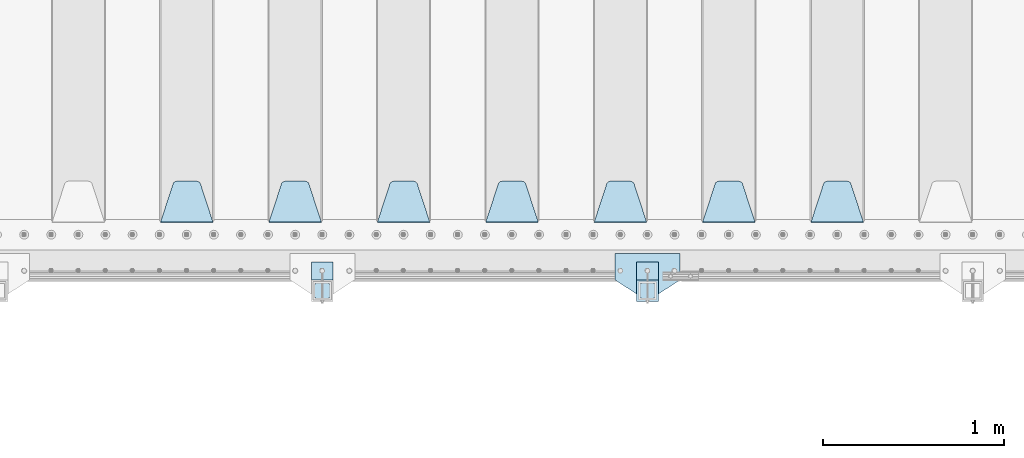
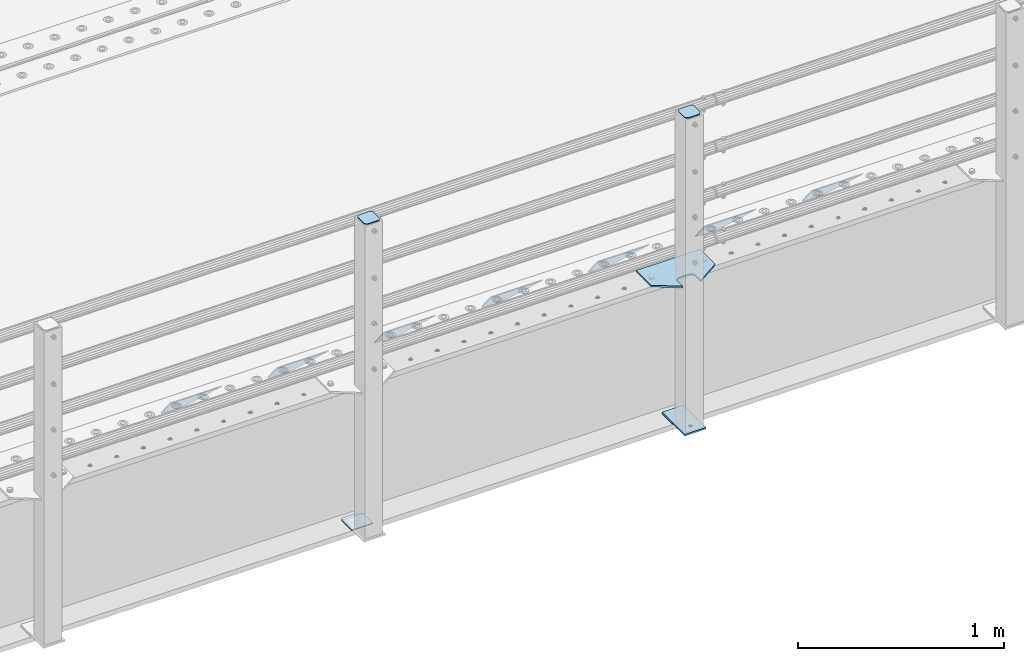
# One storey, part 203 of 247: 13 plates.
"""IFC2X3 building model written with IfcOpenShell, lengths in millimetres."""

import ifcopenshell
import ifcopenshell.guid

model = None  # the IFC model being written
_history = None  # IfcOwnerHistory: only IFC2X3 demands one
_inside = {}  # id of a spatial element -> (the spatial element, [elements in it])
_under = {}  # id of a project, library or spatial element -> (it, [spatial elements below it])
_declared = {}  # id of a project -> (the project, [libraries it declares])
_typed = {}  # id of a type object -> (the type object, [elements of that type])
_made_of = {}  # id of a material, layer set ... -> (it, [elements and type objects made of it])


def new_model(schema):
    """Start an empty IFC model of exactly this schema.

    Asked for "IFC4X3", IfcOpenShell would pick the latest addendum, in which some entities
    have other attributes; the version numbers below select the first issue.
    IFC2X3 requires an IfcOwnerHistory on every rooted entity: one is made here for all.
    """
    global model, _history
    if schema == "IFC4X3":
        model = ifcopenshell.file(schema_version=(4, 3, 0, 0))
    else:
        model = ifcopenshell.file(schema=schema)
    _inside.clear()
    _under.clear()
    _declared.clear()
    _typed.clear()
    _made_of.clear()
    _history = None
    if model.schema == "IFC2X3":
        org = make("IfcOrganization", Name="unknown")
        user = make(
            "IfcPersonAndOrganization",
            ThePerson=make("IfcPerson", FamilyName="unknown"),
            TheOrganization=org,
        )
        app = make(
            "IfcApplication",
            ApplicationDeveloper=org,
            Version="unknown",
            ApplicationFullName="unknown",
            ApplicationIdentifier="unknown",
        )
        _history = make(
            "IfcOwnerHistory",
            OwningUser=user,
            OwningApplication=app,
            ChangeAction="ADDED",
            CreationDate=0,
        )
    return model


def make(cls, **values):
    """One entity of the class cls with the attributes given. An attribute that is None is left unset."""
    return model.create_entity(
        cls, **{name: value for name, value in values.items() if value is not None}
    )


def rooted(cls, **values):
    """An entity with a GlobalId (a new one), such as an element, a storey or a relation."""
    return make(cls, GlobalId=ifcopenshell.guid.new(), OwnerHistory=_history, **values)


def si_unit(unit_type, name, prefix=None):
    """IfcSIUnit, for example si_unit("LENGTHUNIT", "METRE", prefix="MILLI")."""
    return make("IfcSIUnit", UnitType=unit_type, Prefix=prefix, Name=name)


def assignment(units):
    """IfcUnitAssignment: the units of a project."""
    return None if units is None else make("IfcUnitAssignment", Units=units)


def point(xyz):
    """IfcCartesianPoint."""
    return None if xyz is None else make("IfcCartesianPoint", Coordinates=xyz)


def direction(xyz):
    """IfcDirection."""
    return None if xyz is None else make("IfcDirection", DirectionRatios=xyz)


def frame(location, z_axis=None, x_axis=None):
    """IfcAxis2Placement3D, a coordinate frame: its origin and axes. An axis left out is left unset."""
    return make(
        "IfcAxis2Placement3D",
        Location=point(location),
        Axis=direction(z_axis),
        RefDirection=direction(x_axis),
    )


def origin_with_axes():
    """The frame at (0, 0, 0) with the z axis (0, 0, 1) and the x axis (1, 0, 0) written out."""
    return frame((0.0, 0.0, 0.0), z_axis=(0.0, 0.0, 1.0), x_axis=(1.0, 0.0, 0.0))


def place(relative_to, where):
    """IfcLocalPlacement: puts the frame where relative to a parent placement (None: the world)."""
    return make(
        "IfcLocalPlacement", PlacementRelTo=relative_to, RelativePlacement=where
    )


def context(
    kind, dimensions, precision=None, world=None, true_north=None, identifier=None
):
    """IfcGeometricRepresentationContext, for example the 3D "Model" context."""
    return make(
        "IfcGeometricRepresentationContext",
        ContextIdentifier=identifier,
        ContextType=kind,
        CoordinateSpaceDimension=dimensions,
        Precision=precision,
        WorldCoordinateSystem=world,
        TrueNorth=true_north,
    )


def subcontext(parent, identifier, kind, view, scale=None):
    """IfcGeometricRepresentationSubContext, for example "Body" below "Model"."""
    return make(
        "IfcGeometricRepresentationSubContext",
        ContextIdentifier=identifier,
        ContextType=kind,
        ParentContext=parent,
        TargetScale=scale,
        TargetView=view,
    )


def project(units=None, contexts=None):
    """IfcProject with its units and contexts."""
    return rooted(
        "IfcProject",
        Name="project",
        RepresentationContexts=contexts,
        UnitsInContext=assignment(units),
    )


def spatial(cls, under=None, at=None, **own):
    """A site, building, storey or space (cls), placed at a placement, below another one or the project."""
    s = rooted(cls, ObjectPlacement=at, **own)
    if under is not None:
        _under.setdefault(under.id(), (under, []))[1].append(s)
    return s


def faces_of(points, faces, orient=None, outer=None):
    """IfcFace entities. A face is a list of loops; a loop is a list of indices into points, from 0.

    orient and outer hold one flag for each loop. By default every Orientation is true, the
    first loop of a face is its IfcFaceOuterBound and the others are IfcFaceBound.
    """
    made = []
    for i, loops in enumerate(faces):
        bounds = []
        for j, loop in enumerate(loops):
            is_outer = j == 0 if outer is None else outer[i][j]
            bounds.append(
                make(
                    "IfcFaceOuterBound" if is_outer else "IfcFaceBound",
                    Bound=make("IfcPolyLoop", Polygon=[points[k] for k in loop]),
                    Orientation=True if orient is None else orient[i][j],
                )
            )
        made.append(make("IfcFace", Bounds=bounds))
    return made


def faceted_brep(points, faces, orient=None, outer=None, voids=None):
    """IfcFacetedBrep: a solid bounded by flat faces; with voids (closed shells), ...WithVoids."""
    shared = [point(p) for p in points]
    hull = make("IfcClosedShell", CfsFaces=faces_of(shared, faces, orient, outer))
    if voids is None:
        return make("IfcFacetedBrep", Outer=hull)
    return make(
        "IfcFacetedBrepWithVoids",
        Outer=hull,
        Voids=[
            make(cls, CfsFaces=faces_of(shared, fs, o, b)) for cls, fs, o, b in voids
        ],
    )


def shape(context_of_items, identifier, shape_type, items):
    """IfcShapeRepresentation: the items that make up one representation, for example the "Body"."""
    return make(
        "IfcShapeRepresentation",
        ContextOfItems=context_of_items,
        RepresentationIdentifier=identifier,
        RepresentationType=shape_type,
        Items=items,
    )


def material(Name=None, Category=None):
    """IfcMaterial."""
    return make("IfcMaterial", Name=Name, Category=Category)


def made_of(thing, what):
    """Note that an element or type object is made of a material, layer set ...; save() writes the relation."""
    if what is not None:
        _made_of.setdefault(what.id(), (what, []))[1].append(thing)
    return thing


def type_object(cls, material=None, **own):
    """A type object (cls), such as IfcWallType, which elements share."""
    return made_of(rooted(cls, **own), material)


def element(
    cls,
    number,
    at=None,
    inside=None,
    cuts=None,
    type_object=None,
    material=None,
    context=None,
    identifier="Body",
    shape_type=None,
    held_by="IfcProductDefinitionShape",
    body=None,
    shapes=None,
    **own,
):
    """One element of the class cls, such as IfcWall. Its Tag is "e" and its number.

    at: its placement. inside: the storey or other place that contains it. cuts: it is an
    opening in that element (IfcRelVoidsElement). A single representation is given by context,
    identifier, shape_type and body (its items); several are given by shapes. held_by: the class
    of the entity that holds the representations. save() writes the other relations.
    """
    e = rooted(cls, Tag="e%d" % number, ObjectPlacement=at, **own)
    if body is not None:
        shapes = [shape(context, identifier, shape_type, body)]
    if shapes is not None:
        e.Representation = make(held_by, Representations=shapes)
    if inside is not None:
        _inside.setdefault(inside.id(), (inside, []))[1].append(e)
    if cuts is not None:
        rooted(
            "IfcRelVoidsElement", RelatingBuildingElement=cuts, RelatedOpeningElement=e
        )
    if type_object is not None:
        _typed.setdefault(type_object.id(), (type_object, []))[1].append(e)
    return made_of(e, material)


def aggregate(whole, parts):
    """IfcRelAggregates: a whole, such as a stair, and the parts it consists of."""
    return rooted("IfcRelAggregates", RelatingObject=whole, RelatedObjects=parts)


def save(model, path):
    """Write the relations noted so far, then the file.

    IfcRelAggregates (storeys below a building ...), IfcRelContainedInSpatialStructure (elements
    in a storey), IfcRelDefinesByType, IfcRelAssociatesMaterial and IfcRelDeclares: one each for
    every whole, place, type object, material and project.
    """
    for whole, parts in _under.values():
        aggregate(whole, parts)
    for where, things in _inside.values():
        rooted(
            "IfcRelContainedInSpatialStructure",
            RelatedElements=things,
            RelatingStructure=where,
        )
    for kind, things in _typed.values():
        rooted("IfcRelDefinesByType", RelatedObjects=things, RelatingType=kind)
    for what, things in _made_of.values():
        rooted("IfcRelAssociatesMaterial", RelatedObjects=things, RelatingMaterial=what)
    for by, libraries in _declared.values():
        rooted("IfcRelDeclares", RelatingContext=by, RelatedDefinitions=libraries)
    model.write(path)


model = new_model("IFC2X3")

# Units and contexts
model_context = context("Model", 3, precision=1e-05, world=origin_with_axes())
body_context = subcontext(model_context, "Body", "Model", "MODEL_VIEW")
ifc_project = project(units=[si_unit("LENGTHUNIT", "METRE", prefix="MILLI"), si_unit("AREAUNIT", "SQUARE_METRE"), si_unit("VOLUMEUNIT", "CUBIC_METRE"), si_unit("MASSUNIT", "GRAM", prefix="KILO"), si_unit("TIMEUNIT", "SECOND"), si_unit("PLANEANGLEUNIT", "RADIAN"), si_unit("SOLIDANGLEUNIT", "STERADIAN"), si_unit("THERMODYNAMICTEMPERATUREUNIT", "DEGREE_CELSIUS"), si_unit("LUMINOUSINTENSITYUNIT", "LUMEN")], contexts=[model_context])

# Site, building, storey
site_placement = place(None, origin_with_axes())
site = spatial("IfcSite", under=ifc_project, at=site_placement, CompositionType="ELEMENT")
building_placement = place(site_placement, origin_with_axes())
building = spatial("IfcBuilding", under=site, at=building_placement, Name="Standard", CompositionType="ELEMENT")
storey_placement = place(building_placement, origin_with_axes())
storey = spatial("IfcBuildingStorey", under=building, at=storey_placement, Name="Undefined", CompositionType="ELEMENT", Elevation=0.0)

# Plates
ifc_material_1 = material(Name="STEEL/S355N")
plate_type_1 = type_object("IfcPlateType", PredefinedType="NOTDEFINED")
plate_1_placement = place(storey_placement, frame((10745.0, 168.232233047034, -1.76776695296758), z_axis=(0.0, 0.707106781186548, -0.707106781186547), x_axis=(-1.0, 0.0, 0.0)))
element("IfcPlate", 1, at=plate_1_placement, inside=storey, type_object=plate_type_1, material=ifc_material_1, context=body_context, shape_type="Brep", body=[
    faceted_brep([(0.0, -2.49999999999909, 0.0), (69.345504679477, -2.5, 300.17173142483), (69.345504679477, 2.50000000000091, 300.171731424831), (0.0, 2.5, -9.09494701772928e-13), (70.9274061199576, -2.5, 304.897442415399), (70.9274061199576, 2.50000000000091, 304.8974424154), (73.3818627772307, -2.49999999999909, 309.234538108527), (73.3818627772307, 2.5, 309.234538108526), (76.6187032999551, -2.5, 313.023683126102), (76.6187032999551, 2.50000000000091, 313.023683126102), (80.5190132704993, -2.49999999999909, 316.125672595371), (80.5190132704993, 2.50000000000091, 316.125672595372), (84.9395038596849, -2.49999999999909, 318.426546230476), (84.9395038596849, 2.5, 318.426546230475), (89.7177759439219, -2.5, 319.841774983274), (89.7177759439219, 2.50000000000091, 319.841774983275), (94.678286292652, -2.5, 320.319366455077), (94.678286292652, 2.50000000000091, 320.319366455077), (195.321713707348, -2.5, 320.319366455077), (195.321713707348, 2.50000000000091, 320.319366455077), (200.282224056078, -2.5, 319.841774983274), (200.282224056078, 2.50000000000091, 319.841774983275), (205.060496140315, -2.5, 318.426546230475), (205.060496140315, 2.5, 318.426546230474), (209.480986729501, -2.49999999999818, 316.12567259537), (209.480986729501, 2.50000000000091, 316.12567259537), (213.381296700045, -2.5, 313.023683126101), (213.381296700045, 2.50000000000091, 313.023683126101), (216.618137222769, -2.5, 309.234538108525), (216.618137222769, 2.5, 309.234538108525), (219.072593880042, -2.49999999999909, 304.897442415398), (219.072593880042, 2.5, 304.897442415398), (220.654495320523, -2.5, 300.17173142483), (220.654495320523, 2.50000000000091, 300.171731424831), (290.0, -2.49999999999909, 0.0), (290.0, 2.5, -9.09494701772928e-13)], [[[0, 1, 2, 3]], [[1, 4, 5, 2]], [[4, 6, 7, 5]], [[6, 8, 9, 7]], [[8, 10, 11, 9]], [[10, 12, 13, 11]], [[12, 14, 15, 13]], [[14, 16, 17, 15]], [[16, 18, 19, 17]], [[18, 20, 21, 19]], [[20, 22, 23, 21]], [[22, 24, 25, 23]], [[24, 26, 27, 25]], [[26, 28, 29, 27]], [[28, 30, 31, 29]], [[30, 32, 33, 31]], [[32, 34, 35, 33]], [[34, 0, 3, 35]], [[5, 7, 9, 11, 13, 15, 17, 19, 21, 23, 25, 27, 29, 31, 33, 35, 3, 2]], [[34, 32, 30, 28, 26, 24, 22, 20, 18, 16, 14, 12, 10, 8, 6, 4, 1, 0]]]),
])
plate_2_placement = place(storey_placement, frame((10145.0, 168.232233047034, -1.76776695296758), z_axis=(0.0, 0.707106781186548, -0.707106781186547), x_axis=(-1.0, 0.0, 0.0)))
element("IfcPlate", 2, at=plate_2_placement, inside=storey, type_object=plate_type_1, material=ifc_material_1, context=body_context, shape_type="Brep", body=[
    faceted_brep([(0.0, -2.49999999999909, 0.0), (69.345504679477, -2.5, 300.17173142483), (69.345504679477, 2.50000000000091, 300.171731424831), (0.0, 2.5, -9.09494701772928e-13), (70.9274061199576, -2.5, 304.897442415399), (70.9274061199576, 2.50000000000091, 304.8974424154), (73.3818627772307, -2.49999999999909, 309.234538108527), (73.3818627772307, 2.5, 309.234538108526), (76.6187032999551, -2.5, 313.023683126102), (76.6187032999551, 2.50000000000091, 313.023683126102), (80.5190132704993, -2.49999999999909, 316.125672595371), (80.5190132704993, 2.50000000000091, 316.125672595372), (84.9395038596849, -2.49999999999909, 318.426546230476), (84.9395038596849, 2.5, 318.426546230475), (89.7177759439219, -2.5, 319.841774983274), (89.7177759439219, 2.50000000000091, 319.841774983275), (94.678286292652, -2.5, 320.319366455077), (94.678286292652, 2.50000000000091, 320.319366455077), (195.321713707348, -2.5, 320.319366455077), (195.321713707348, 2.50000000000091, 320.319366455077), (200.282224056078, -2.5, 319.841774983274), (200.282224056078, 2.50000000000091, 319.841774983275), (205.060496140315, -2.5, 318.426546230475), (205.060496140315, 2.5, 318.426546230474), (209.480986729501, -2.49999999999818, 316.12567259537), (209.480986729501, 2.50000000000091, 316.12567259537), (213.381296700045, -2.5, 313.023683126101), (213.381296700045, 2.50000000000091, 313.023683126101), (216.618137222769, -2.5, 309.234538108525), (216.618137222769, 2.5, 309.234538108525), (219.072593880042, -2.49999999999909, 304.897442415398), (219.072593880042, 2.5, 304.897442415398), (220.654495320523, -2.5, 300.17173142483), (220.654495320523, 2.50000000000091, 300.171731424831), (290.0, -2.49999999999909, 0.0), (290.0, 2.5, -9.09494701772928e-13)], [[[0, 1, 2, 3]], [[1, 4, 5, 2]], [[4, 6, 7, 5]], [[6, 8, 9, 7]], [[8, 10, 11, 9]], [[10, 12, 13, 11]], [[12, 14, 15, 13]], [[14, 16, 17, 15]], [[16, 18, 19, 17]], [[18, 20, 21, 19]], [[20, 22, 23, 21]], [[22, 24, 25, 23]], [[24, 26, 27, 25]], [[26, 28, 29, 27]], [[28, 30, 31, 29]], [[30, 32, 33, 31]], [[32, 34, 35, 33]], [[34, 0, 3, 35]], [[5, 7, 9, 11, 13, 15, 17, 19, 21, 23, 25, 27, 29, 31, 33, 35, 3, 2]], [[34, 32, 30, 28, 26, 24, 22, 20, 18, 16, 14, 12, 10, 8, 6, 4, 1, 0]]]),
])
plate_3_placement = place(storey_placement, frame((9545.0, 168.232233047034, -1.76776695296758), z_axis=(0.0, 0.707106781186548, -0.707106781186547), x_axis=(-1.0, 0.0, 0.0)))
element("IfcPlate", 3, at=plate_3_placement, inside=storey, type_object=plate_type_1, material=ifc_material_1, context=body_context, shape_type="Brep", body=[
    faceted_brep([(0.0, -2.49999999999909, 0.0), (69.345504679477, -2.5, 300.17173142483), (69.345504679477, 2.50000000000091, 300.171731424831), (0.0, 2.5, -9.09494701772928e-13), (70.9274061199576, -2.5, 304.897442415399), (70.9274061199576, 2.50000000000091, 304.8974424154), (73.3818627772307, -2.49999999999909, 309.234538108527), (73.3818627772307, 2.5, 309.234538108526), (76.6187032999551, -2.5, 313.023683126102), (76.6187032999551, 2.50000000000091, 313.023683126102), (80.5190132704993, -2.49999999999909, 316.125672595371), (80.5190132704993, 2.50000000000091, 316.125672595372), (84.9395038596849, -2.49999999999909, 318.426546230476), (84.9395038596849, 2.5, 318.426546230475), (89.7177759439219, -2.5, 319.841774983274), (89.7177759439219, 2.50000000000091, 319.841774983275), (94.678286292652, -2.5, 320.319366455077), (94.678286292652, 2.50000000000091, 320.319366455077), (195.321713707348, -2.5, 320.319366455077), (195.321713707348, 2.50000000000091, 320.319366455077), (200.282224056078, -2.5, 319.841774983274), (200.282224056078, 2.50000000000091, 319.841774983275), (205.060496140315, -2.5, 318.426546230475), (205.060496140315, 2.5, 318.426546230474), (209.480986729501, -2.49999999999818, 316.12567259537), (209.480986729501, 2.50000000000091, 316.12567259537), (213.381296700045, -2.5, 313.023683126101), (213.381296700045, 2.50000000000091, 313.023683126101), (216.618137222769, -2.5, 309.234538108525), (216.618137222769, 2.5, 309.234538108525), (219.072593880042, -2.49999999999909, 304.897442415398), (219.072593880042, 2.5, 304.897442415398), (220.654495320523, -2.5, 300.17173142483), (220.654495320523, 2.50000000000091, 300.171731424831), (290.0, -2.49999999999909, 0.0), (290.0, 2.5, -9.09494701772928e-13)], [[[0, 1, 2, 3]], [[1, 4, 5, 2]], [[4, 6, 7, 5]], [[6, 8, 9, 7]], [[8, 10, 11, 9]], [[10, 12, 13, 11]], [[12, 14, 15, 13]], [[14, 16, 17, 15]], [[16, 18, 19, 17]], [[18, 20, 21, 19]], [[20, 22, 23, 21]], [[22, 24, 25, 23]], [[24, 26, 27, 25]], [[26, 28, 29, 27]], [[28, 30, 31, 29]], [[30, 32, 33, 31]], [[32, 34, 35, 33]], [[34, 0, 3, 35]], [[5, 7, 9, 11, 13, 15, 17, 19, 21, 23, 25, 27, 29, 31, 33, 35, 3, 2]], [[34, 32, 30, 28, 26, 24, 22, 20, 18, 16, 14, 12, 10, 8, 6, 4, 1, 0]]]),
])
plate_4_placement = place(storey_placement, frame((8945.0, 168.232233047034, -1.76776695296758), z_axis=(0.0, 0.707106781186548, -0.707106781186547), x_axis=(-1.0, 0.0, 0.0)))
element("IfcPlate", 4, at=plate_4_placement, inside=storey, type_object=plate_type_1, material=ifc_material_1, context=body_context, shape_type="Brep", body=[
    faceted_brep([(0.0, -2.49999999999909, 0.0), (69.345504679477, -2.5, 300.17173142483), (69.345504679477, 2.50000000000091, 300.171731424831), (0.0, 2.5, -9.09494701772928e-13), (70.9274061199576, -2.5, 304.897442415399), (70.9274061199576, 2.50000000000091, 304.8974424154), (73.3818627772307, -2.49999999999909, 309.234538108527), (73.3818627772307, 2.5, 309.234538108526), (76.6187032999551, -2.5, 313.023683126102), (76.6187032999551, 2.50000000000091, 313.023683126102), (80.5190132704993, -2.49999999999909, 316.125672595371), (80.5190132704993, 2.50000000000091, 316.125672595372), (84.9395038596849, -2.49999999999909, 318.426546230476), (84.9395038596849, 2.5, 318.426546230475), (89.7177759439219, -2.5, 319.841774983274), (89.7177759439219, 2.50000000000091, 319.841774983275), (94.678286292652, -2.5, 320.319366455077), (94.678286292652, 2.50000000000091, 320.319366455077), (195.321713707348, -2.5, 320.319366455077), (195.321713707348, 2.50000000000091, 320.319366455077), (200.282224056078, -2.5, 319.841774983274), (200.282224056078, 2.50000000000091, 319.841774983275), (205.060496140315, -2.5, 318.426546230475), (205.060496140315, 2.5, 318.426546230474), (209.480986729501, -2.49999999999818, 316.12567259537), (209.480986729501, 2.50000000000091, 316.12567259537), (213.381296700045, -2.5, 313.023683126101), (213.381296700045, 2.50000000000091, 313.023683126101), (216.618137222769, -2.5, 309.234538108525), (216.618137222769, 2.5, 309.234538108525), (219.072593880042, -2.49999999999909, 304.897442415398), (219.072593880042, 2.5, 304.897442415398), (220.654495320523, -2.5, 300.17173142483), (220.654495320523, 2.50000000000091, 300.171731424831), (290.0, -2.49999999999909, 0.0), (290.0, 2.5, -9.09494701772928e-13)], [[[0, 1, 2, 3]], [[1, 4, 5, 2]], [[4, 6, 7, 5]], [[6, 8, 9, 7]], [[8, 10, 11, 9]], [[10, 12, 13, 11]], [[12, 14, 15, 13]], [[14, 16, 17, 15]], [[16, 18, 19, 17]], [[18, 20, 21, 19]], [[20, 22, 23, 21]], [[22, 24, 25, 23]], [[24, 26, 27, 25]], [[26, 28, 29, 27]], [[28, 30, 31, 29]], [[30, 32, 33, 31]], [[32, 34, 35, 33]], [[34, 0, 3, 35]], [[5, 7, 9, 11, 13, 15, 17, 19, 21, 23, 25, 27, 29, 31, 33, 35, 3, 2]], [[34, 32, 30, 28, 26, 24, 22, 20, 18, 16, 14, 12, 10, 8, 6, 4, 1, 0]]]),
])
plate_5_placement = place(storey_placement, frame((8345.0, 168.232233047034, -1.76776695296758), z_axis=(0.0, 0.707106781186548, -0.707106781186547), x_axis=(-1.0, 0.0, 0.0)))
element("IfcPlate", 5, at=plate_5_placement, inside=storey, type_object=plate_type_1, material=ifc_material_1, context=body_context, shape_type="Brep", body=[
    faceted_brep([(0.0, -2.49999999999909, 0.0), (69.345504679477, -2.5, 300.17173142483), (69.345504679477, 2.50000000000091, 300.171731424831), (0.0, 2.5, -9.09494701772928e-13), (70.9274061199576, -2.5, 304.897442415399), (70.9274061199576, 2.50000000000091, 304.8974424154), (73.3818627772307, -2.49999999999909, 309.234538108527), (73.3818627772307, 2.5, 309.234538108526), (76.6187032999551, -2.5, 313.023683126102), (76.6187032999551, 2.50000000000091, 313.023683126102), (80.5190132704993, -2.49999999999909, 316.125672595371), (80.5190132704993, 2.50000000000091, 316.125672595372), (84.9395038596849, -2.49999999999909, 318.426546230476), (84.9395038596849, 2.5, 318.426546230475), (89.7177759439219, -2.5, 319.841774983274), (89.7177759439219, 2.50000000000091, 319.841774983275), (94.678286292652, -2.5, 320.319366455077), (94.678286292652, 2.50000000000091, 320.319366455077), (195.321713707348, -2.5, 320.319366455077), (195.321713707348, 2.50000000000091, 320.319366455077), (200.282224056078, -2.5, 319.841774983274), (200.282224056078, 2.50000000000091, 319.841774983275), (205.060496140315, -2.5, 318.426546230475), (205.060496140315, 2.5, 318.426546230474), (209.480986729501, -2.49999999999818, 316.12567259537), (209.480986729501, 2.50000000000091, 316.12567259537), (213.381296700045, -2.5, 313.023683126101), (213.381296700045, 2.50000000000091, 313.023683126101), (216.618137222769, -2.5, 309.234538108525), (216.618137222769, 2.5, 309.234538108525), (219.072593880042, -2.49999999999909, 304.897442415398), (219.072593880042, 2.5, 304.897442415398), (220.654495320523, -2.5, 300.17173142483), (220.654495320523, 2.50000000000091, 300.171731424831), (290.0, -2.49999999999909, 0.0), (290.0, 2.5, -9.09494701772928e-13)], [[[0, 1, 2, 3]], [[1, 4, 5, 2]], [[4, 6, 7, 5]], [[6, 8, 9, 7]], [[8, 10, 11, 9]], [[10, 12, 13, 11]], [[12, 14, 15, 13]], [[14, 16, 17, 15]], [[16, 18, 19, 17]], [[18, 20, 21, 19]], [[20, 22, 23, 21]], [[22, 24, 25, 23]], [[24, 26, 27, 25]], [[26, 28, 29, 27]], [[28, 30, 31, 29]], [[30, 32, 33, 31]], [[32, 34, 35, 33]], [[34, 0, 3, 35]], [[5, 7, 9, 11, 13, 15, 17, 19, 21, 23, 25, 27, 29, 31, 33, 35, 3, 2]], [[34, 32, 30, 28, 26, 24, 22, 20, 18, 16, 14, 12, 10, 8, 6, 4, 1, 0]]]),
])
plate_6_placement = place(storey_placement, frame((7745.0, 168.232233047034, -1.76776695296758), z_axis=(0.0, 0.707106781186548, -0.707106781186547), x_axis=(-1.0, 0.0, 0.0)))
element("IfcPlate", 6, at=plate_6_placement, inside=storey, type_object=plate_type_1, material=ifc_material_1, context=body_context, shape_type="Brep", body=[
    faceted_brep([(0.0, -2.49999999999909, 0.0), (69.345504679477, -2.5, 300.17173142483), (69.345504679477, 2.50000000000091, 300.171731424831), (0.0, 2.5, -9.09494701772928e-13), (70.9274061199576, -2.5, 304.897442415399), (70.9274061199576, 2.50000000000091, 304.8974424154), (73.3818627772307, -2.49999999999909, 309.234538108527), (73.3818627772307, 2.5, 309.234538108526), (76.6187032999551, -2.5, 313.023683126102), (76.6187032999551, 2.50000000000091, 313.023683126102), (80.5190132704993, -2.49999999999909, 316.125672595371), (80.5190132704993, 2.50000000000091, 316.125672595372), (84.9395038596849, -2.49999999999909, 318.426546230476), (84.9395038596849, 2.5, 318.426546230475), (89.7177759439219, -2.5, 319.841774983274), (89.7177759439219, 2.50000000000091, 319.841774983275), (94.678286292652, -2.5, 320.319366455077), (94.678286292652, 2.50000000000091, 320.319366455077), (195.321713707348, -2.5, 320.319366455077), (195.321713707348, 2.50000000000091, 320.319366455077), (200.282224056078, -2.5, 319.841774983274), (200.282224056078, 2.50000000000091, 319.841774983275), (205.060496140315, -2.5, 318.426546230475), (205.060496140315, 2.5, 318.426546230474), (209.480986729501, -2.49999999999818, 316.12567259537), (209.480986729501, 2.50000000000091, 316.12567259537), (213.381296700045, -2.5, 313.023683126101), (213.381296700045, 2.50000000000091, 313.023683126101), (216.618137222769, -2.5, 309.234538108525), (216.618137222769, 2.5, 309.234538108525), (219.072593880042, -2.49999999999909, 304.897442415398), (219.072593880042, 2.5, 304.897442415398), (220.654495320523, -2.5, 300.17173142483), (220.654495320523, 2.50000000000091, 300.171731424831), (290.0, -2.49999999999909, 0.0), (290.0, 2.5, -9.09494701772928e-13)], [[[0, 1, 2, 3]], [[1, 4, 5, 2]], [[4, 6, 7, 5]], [[6, 8, 9, 7]], [[8, 10, 11, 9]], [[10, 12, 13, 11]], [[12, 14, 15, 13]], [[14, 16, 17, 15]], [[16, 18, 19, 17]], [[18, 20, 21, 19]], [[20, 22, 23, 21]], [[22, 24, 25, 23]], [[24, 26, 27, 25]], [[26, 28, 29, 27]], [[28, 30, 31, 29]], [[30, 32, 33, 31]], [[32, 34, 35, 33]], [[34, 0, 3, 35]], [[5, 7, 9, 11, 13, 15, 17, 19, 21, 23, 25, 27, 29, 31, 33, 35, 3, 2]], [[34, 32, 30, 28, 26, 24, 22, 20, 18, 16, 14, 12, 10, 8, 6, 4, 1, 0]]]),
])
plate_7_placement = place(storey_placement, frame((7145.0, 168.232233047034, -1.76776695296758), z_axis=(0.0, 0.707106781186548, -0.707106781186547), x_axis=(-1.0, 0.0, 0.0)))
element("IfcPlate", 7, at=plate_7_placement, inside=storey, type_object=plate_type_1, material=ifc_material_1, context=body_context, shape_type="Brep", body=[
    faceted_brep([(0.0, -2.49999999999909, 0.0), (69.345504679477, -2.5, 300.17173142483), (69.345504679477, 2.50000000000091, 300.171731424831), (0.0, 2.5, -9.09494701772928e-13), (70.9274061199576, -2.5, 304.897442415399), (70.9274061199576, 2.50000000000091, 304.8974424154), (73.3818627772307, -2.49999999999909, 309.234538108527), (73.3818627772307, 2.5, 309.234538108526), (76.6187032999551, -2.5, 313.023683126102), (76.6187032999551, 2.50000000000091, 313.023683126102), (80.5190132704993, -2.49999999999909, 316.125672595371), (80.5190132704993, 2.50000000000091, 316.125672595372), (84.9395038596849, -2.49999999999909, 318.426546230476), (84.9395038596849, 2.5, 318.426546230475), (89.7177759439219, -2.5, 319.841774983274), (89.7177759439219, 2.50000000000091, 319.841774983275), (94.678286292652, -2.5, 320.319366455077), (94.678286292652, 2.50000000000091, 320.319366455077), (195.321713707348, -2.5, 320.319366455077), (195.321713707348, 2.50000000000091, 320.319366455077), (200.282224056078, -2.5, 319.841774983274), (200.282224056078, 2.50000000000091, 319.841774983275), (205.060496140315, -2.5, 318.426546230475), (205.060496140315, 2.5, 318.426546230474), (209.480986729501, -2.49999999999818, 316.12567259537), (209.480986729501, 2.50000000000091, 316.12567259537), (213.381296700045, -2.5, 313.023683126101), (213.381296700045, 2.50000000000091, 313.023683126101), (216.618137222769, -2.5, 309.234538108525), (216.618137222769, 2.5, 309.234538108525), (219.072593880042, -2.49999999999909, 304.897442415398), (219.072593880042, 2.5, 304.897442415398), (220.654495320523, -2.5, 300.17173142483), (220.654495320523, 2.50000000000091, 300.171731424831), (290.0, -2.49999999999909, 0.0), (290.0, 2.5, -9.09494701772928e-13)], [[[0, 1, 2, 3]], [[1, 4, 5, 2]], [[4, 6, 7, 5]], [[6, 8, 9, 7]], [[8, 10, 11, 9]], [[10, 12, 13, 11]], [[12, 14, 15, 13]], [[14, 16, 17, 15]], [[16, 18, 19, 17]], [[18, 20, 21, 19]], [[20, 22, 23, 21]], [[22, 24, 25, 23]], [[24, 26, 27, 25]], [[26, 28, 29, 27]], [[28, 30, 31, 29]], [[30, 32, 33, 31]], [[32, 34, 35, 33]], [[34, 0, 3, 35]], [[5, 7, 9, 11, 13, 15, 17, 19, 21, 23, 25, 27, 29, 31, 33, 35, 3, 2]], [[34, 32, 30, 28, 26, 24, 22, 20, 18, 16, 14, 12, 10, 8, 6, 4, 1, 0]]]),
])
ifc_material_2 = material(Name="STEEL/S355J2")
plate_type_2 = type_object("IfcPlateType", PredefinedType="NOTDEFINED")
plate_8_placement = place(storey_placement, frame((9730.0, -4.99999999999636, 5.00000000004911), z_axis=(0.0, -0.999999999999548, -9.5100000000016e-07), x_axis=(-1.0, 0.0, 0.0)))
element("IfcPlate", 8, at=plate_8_placement, inside=storey, type_object=plate_type_2, material=ifc_material_2, context=body_context, shape_type="Brep", body=[
    faceted_brep([(9.04219632502645e-09, -5.00000000143385, -2.89173840428703e-09), (2.31396552408114e-06, -5.0, 145.0), (2.31396552408114e-06, 5.0, 145.0), (7.66340235713869e-09, 4.99999999856618, -2.89173840428703e-09), (130.0, -5.0, 230.0), (130.0, 5.0, 230.0), (130.0, -5.0, 180.0), (130.0, 5.0, 180.0), (130.48036798992, -5.0, 175.122741949597), (130.48036798992, 5.0, 175.122741949597), (131.903011687218, -5.0, 170.432914190873), (131.903011687218, 5.0, 170.432914190873), (134.213259692437, -5.0, 166.11074417451), (134.213259692437, 5.0, 166.11074417451), (137.322330470337, -5.0, 162.322330470337), (137.322330470337, 5.0, 162.322330470337), (141.11074417451, -5.0, 159.213259692437), (141.11074417451, 5.0, 159.213259692437), (145.432914190873, -5.0, 156.903011687218), (145.432914190873, 5.0, 156.903011687218), (150.122741949597, -5.0, 155.48036798992), (150.122741949597, 5.0, 155.48036798992), (155.0, -5.0, 155.0), (155.0, 5.0, 155.0), (205.0, -5.0, 155.0), (205.0, 5.0, 155.0), (209.877258050403, -5.0, 155.48036798992), (209.877258050403, 5.0, 155.48036798992), (214.567085809127, -5.0, 156.903011687218), (214.567085809127, 5.0, 156.903011687218), (218.88925582549, -5.0, 159.213259692437), (218.88925582549, 5.0, 159.213259692437), (222.677669529663, -5.0, 162.322330470337), (222.677669529663, 5.0, 162.322330470337), (225.786740307563, -5.0, 166.11074417451), (225.786740307563, 5.0, 166.11074417451), (228.096988312782, -5.0, 170.432914190873), (228.096988312782, 5.0, 170.432914190873), (229.51963201008, -5.0, 175.122741949597), (229.51963201008, 5.0, 175.122741949597), (230.0, -5.0, 180.0), (230.0, 5.0, 180.0), (230.0, -5.0, 230.0), (230.0, 5.0, 230.0), (360.0, -5.0, 145.0), (360.0, 5.0, 145.0), (360.0, -5.0, -7.27595761418343e-12), (360.0, 5.0, -7.27595761418343e-12)], [[[0, 1, 2, 3]], [[1, 4, 5, 2]], [[4, 6, 7, 5]], [[6, 8, 9, 7]], [[8, 10, 11, 9]], [[10, 12, 13, 11]], [[12, 14, 15, 13]], [[14, 16, 17, 15]], [[16, 18, 19, 17]], [[18, 20, 21, 19]], [[20, 22, 23, 21]], [[22, 24, 25, 23]], [[24, 26, 27, 25]], [[26, 28, 29, 27]], [[28, 30, 31, 29]], [[30, 32, 33, 31]], [[32, 34, 35, 33]], [[34, 36, 37, 35]], [[36, 38, 39, 37]], [[38, 40, 41, 39]], [[40, 42, 43, 41]], [[42, 44, 45, 43]], [[44, 46, 47, 45]], [[46, 0, 3, 47]], [[5, 7, 9, 11, 13, 15, 17, 19, 21, 23, 25, 27, 29, 31, 33, 35, 37, 39, 41, 43, 45, 47, 3, 2]], [[46, 44, 42, 40, 38, 36, 34, 32, 30, 28, 26, 24, 22, 20, 18, 16, 14, 12, 10, 8, 6, 4, 1, 0]]]),
])
plate_type_3 = type_object("IfcPlateType", PredefinedType="NOTDEFINED")
plate_9_placement = place(storey_placement, frame((9609.99999999986, -50.0000000002074, -850.000000000002), z_axis=(0.0, -0.999999999999548, -9.5100000000016e-07), x_axis=(-1.0, 0.0, 0.0)))
element("IfcPlate", 9, at=plate_9_placement, inside=storey, type_object=plate_type_3, material=ifc_material_2, context=body_context, shape_type="Brep", body=[
    faceted_brep([(53.6360389691836, -5.0, 176.363961030469), (53.6360389691836, 5.0, 176.363961030469), (59.9999999998618, 5.0, 178.999999999791), (59.9999999998618, -5.0, 178.999999999791), (66.3639610305399, 5.0, 176.363961030469), (66.3639610305399, -5.0, 176.363961030469), (68.9999999998618, 5.0, 169.999999999791), (68.9999999998618, -5.0, 169.999999999791), (66.3639610305399, 5.0, 163.636038969113), (66.3639610305399, -5.0, 163.636038969113), (59.9999999998618, 5.0, 160.999999999791), (59.9999999998618, -5.0, 160.999999999791), (53.6360389691836, 5.0, 163.636038969113), (53.6360389691836, -5.0, 163.636038969113), (50.9999999998618, 5.0, 169.999999999791), (50.9999999998618, -5.0, 169.999999999791), (120.0, -5.0, 0.0), (120.0, -5.0, 220.0), (0.0, -5.0, 220.0), (9.04219632502645e-09, -5.00000000143385, -2.89173840428703e-09), (7.66340235713869e-09, 4.99999999856618, -2.89173840428703e-09), (120.0, 5.0, 0.0), (120.0, 5.0, 220.0), (0.0, 5.0, 220.0)], [[[0, 1, 2, 3]], [[3, 2, 4, 5]], [[5, 4, 6, 7]], [[7, 6, 8, 9]], [[9, 8, 10, 11]], [[11, 10, 12, 13]], [[13, 12, 14, 15]], [[15, 14, 1, 0]], [[16, 17, 18, 19], [11, 13, 15, 0, 3, 5, 7, 9]], [[16, 19, 20, 21]], [[17, 16, 21, 22]], [[18, 17, 22, 23]], [[19, 18, 23, 20]], [[22, 21, 20, 23], [2, 1, 14, 12, 10, 8, 6, 4]]]),
])
plate_type_4 = type_object("IfcPlateType", PredefinedType="NOTDEFINED")
plate_10_placement = place(storey_placement, frame((9505.99999999987, -166.000000000207, 1012.50000000001), z_axis=(0.0, -0.999999999999548, -9.5100000000016e-07), x_axis=(1.0, 0.0, 0.0)))
element("IfcPlate", 10, at=plate_10_placement, inside=storey, type_object=plate_type_4, material=ifc_material_2, context=body_context, shape_type="Brep", body=[
    faceted_brep([(0.0, -2.5, 19.0), (0.0, -2.5, 69.0), (0.0, 2.5, 69.0), (0.0, 2.5, 19.0), (0.476369668545885, -2.5, 73.2278977451697), (0.476369668545885, 2.5, 73.2278977451697), (1.88159150985484, -2.5, 77.2437910432327), (1.88159150985484, 2.5, 77.2437910432327), (4.14520183310742, -2.5, 80.8463062353167), (4.14520183310742, 2.5, 80.8463062353167), (7.15369376468334, -2.5, 83.8547981668926), (7.15369376468334, 2.5, 83.8547981668926), (10.7562089567673, -2.5, 86.1184084901452), (10.7562089567673, 2.5, 86.1184084901452), (14.7721022548303, -2.5, 87.5236303314541), (14.7721022548303, 2.5, 87.5236303314541), (19.0, -2.5, 88.0), (19.0, 2.5, 88.0), (69.0, -2.5, 88.0), (69.0, 2.5, 88.0), (73.2278977451697, -2.5, 87.5236303314541), (73.2278977451697, 2.5, 87.5236303314541), (77.2437910432327, -2.5, 86.1184084901452), (77.2437910432327, 2.5, 86.1184084901452), (80.8463062353167, -2.5, 83.8547981668926), (80.8463062353167, 2.5, 83.8547981668926), (83.8547981668926, -2.5, 80.8463062353167), (83.8547981668926, 2.5, 80.8463062353167), (86.1184084901452, -2.5, 77.2437910432327), (86.1184084901452, 2.5, 77.2437910432327), (87.5236303314541, -2.5, 73.2278977451697), (87.5236303314541, 2.5, 73.2278977451697), (88.0, -2.5, 69.0), (88.0, 2.5, 69.0), (88.0, -2.5, 19.0), (88.0, 2.5, 19.0), (87.5236303314541, -2.5, 14.7721022548303), (87.5236303314541, 2.5, 14.7721022548303), (86.1184084901452, -2.5, 10.7562089567673), (86.1184084901452, 2.5, 10.7562089567673), (83.8547981668926, -2.5, 7.15369376468334), (83.8547981668926, 2.5, 7.15369376468334), (80.8463062353167, -2.5, 4.14520183310742), (80.8463062353167, 2.5, 4.14520183310742), (77.2437910432345, -2.5, 1.88159150985484), (77.2437910432345, 2.5, 1.88159150985484), (73.2278977451697, -2.5, 0.476369668545885), (73.2278977451697, 2.5, 0.476369668545885), (69.0, -2.5, 0.0), (69.0, 2.5, 0.0), (19.0, -2.5, 0.0), (19.0, 2.5, 0.0), (14.7721022548303, -2.5, 0.476369668545885), (14.7721022548303, 2.5, 0.476369668545885), (10.7562089567673, -2.5, 1.88159150985484), (10.7562089567673, 2.5, 1.88159150985484), (7.15369376468334, -2.5, 4.14520183310742), (7.15369376468334, 2.5, 4.14520183310742), (4.14520183310742, -2.5, 7.15369376468334), (4.14520183310742, 2.5, 7.15369376468334), (1.88159150985484, -2.5, 10.7562089567673), (1.88159150985484, 2.5, 10.7562089567673), (0.476369668545885, -2.5, 14.7721022548303), (0.476369668545885, 2.5, 14.7721022548303)], [[[0, 1, 2, 3]], [[1, 4, 5, 2]], [[4, 6, 7, 5]], [[6, 8, 9, 7]], [[8, 10, 11, 9]], [[10, 12, 13, 11]], [[12, 14, 15, 13]], [[14, 16, 17, 15]], [[16, 18, 19, 17]], [[18, 20, 21, 19]], [[20, 22, 23, 21]], [[22, 24, 25, 23]], [[24, 26, 27, 25]], [[26, 28, 29, 27]], [[28, 30, 31, 29]], [[30, 32, 33, 31]], [[32, 34, 35, 33]], [[34, 36, 37, 35]], [[36, 38, 39, 37]], [[38, 40, 41, 39]], [[40, 42, 43, 41]], [[42, 44, 45, 43]], [[44, 46, 47, 45]], [[46, 48, 49, 47]], [[48, 50, 51, 49]], [[50, 52, 53, 51]], [[52, 54, 55, 53]], [[54, 56, 57, 55]], [[56, 58, 59, 57]], [[58, 60, 61, 59]], [[60, 62, 63, 61]], [[62, 0, 3, 63]], [[5, 7, 9, 11, 13, 15, 17, 19, 21, 23, 25, 27, 29, 31, 33, 35, 37, 39, 41, 43, 45, 47, 49, 51, 53, 55, 57, 59, 61, 63, 3, 2]], [[62, 60, 58, 56, 54, 52, 50, 48, 46, 44, 42, 40, 38, 36, 34, 32, 30, 28, 26, 24, 22, 20, 18, 16, 14, 12, 10, 8, 6, 4, 1, 0]]]),
])
plate_11_placement = place(storey_placement, frame((7705.99999999987, -166.000000000207, 1012.50000000001), z_axis=(0.0, -0.999999999999548, -9.5100000000016e-07), x_axis=(1.0, 0.0, 0.0)))
element("IfcPlate", 11, at=plate_11_placement, inside=storey, type_object=plate_type_4, material=ifc_material_2, context=body_context, shape_type="Brep", body=[
    faceted_brep([(0.0, -2.5, 19.0), (0.0, -2.5, 69.0), (0.0, 2.5, 69.0), (0.0, 2.5, 19.0), (0.476369668545885, -2.5, 73.2278977451697), (0.476369668545885, 2.5, 73.2278977451697), (1.88159150985484, -2.5, 77.2437910432327), (1.88159150985484, 2.5, 77.2437910432327), (4.14520183310742, -2.5, 80.8463062353167), (4.14520183310742, 2.5, 80.8463062353167), (7.15369376468334, -2.5, 83.8547981668926), (7.15369376468334, 2.5, 83.8547981668926), (10.7562089567673, -2.5, 86.1184084901452), (10.7562089567673, 2.5, 86.1184084901452), (14.7721022548303, -2.5, 87.5236303314541), (14.7721022548303, 2.5, 87.5236303314541), (19.0, -2.5, 88.0), (19.0, 2.5, 88.0), (69.0, -2.5, 88.0), (69.0, 2.5, 88.0), (73.2278977451697, -2.5, 87.5236303314541), (73.2278977451697, 2.5, 87.5236303314541), (77.2437910432327, -2.5, 86.1184084901452), (77.2437910432327, 2.5, 86.1184084901452), (80.8463062353167, -2.5, 83.8547981668926), (80.8463062353167, 2.5, 83.8547981668926), (83.8547981668926, -2.5, 80.8463062353167), (83.8547981668926, 2.5, 80.8463062353167), (86.1184084901452, -2.5, 77.2437910432327), (86.1184084901452, 2.5, 77.2437910432327), (87.5236303314541, -2.5, 73.2278977451697), (87.5236303314541, 2.5, 73.2278977451697), (88.0, -2.5, 69.0), (88.0, 2.5, 69.0), (88.0, -2.5, 19.0), (88.0, 2.5, 19.0), (87.5236303314541, -2.5, 14.7721022548303), (87.5236303314541, 2.5, 14.7721022548303), (86.1184084901452, -2.5, 10.7562089567673), (86.1184084901452, 2.5, 10.7562089567673), (83.8547981668926, -2.5, 7.15369376468334), (83.8547981668926, 2.5, 7.15369376468334), (80.8463062353167, -2.5, 4.14520183310742), (80.8463062353167, 2.5, 4.14520183310742), (77.2437910432345, -2.5, 1.88159150985484), (77.2437910432345, 2.5, 1.88159150985484), (73.2278977451697, -2.5, 0.476369668545885), (73.2278977451697, 2.5, 0.476369668545885), (69.0, -2.5, 0.0), (69.0, 2.5, 0.0), (19.0, -2.5, 0.0), (19.0, 2.5, 0.0), (14.7721022548303, -2.5, 0.476369668545885), (14.7721022548303, 2.5, 0.476369668545885), (10.7562089567673, -2.5, 1.88159150985484), (10.7562089567673, 2.5, 1.88159150985484), (7.15369376468334, -2.5, 4.14520183310742), (7.15369376468334, 2.5, 4.14520183310742), (4.14520183310742, -2.5, 7.15369376468334), (4.14520183310742, 2.5, 7.15369376468334), (1.88159150985484, -2.5, 10.7562089567673), (1.88159150985484, 2.5, 10.7562089567673), (0.476369668545885, -2.5, 14.7721022548303), (0.476369668545885, 2.5, 14.7721022548303)], [[[0, 1, 2, 3]], [[1, 4, 5, 2]], [[4, 6, 7, 5]], [[6, 8, 9, 7]], [[8, 10, 11, 9]], [[10, 12, 13, 11]], [[12, 14, 15, 13]], [[14, 16, 17, 15]], [[16, 18, 19, 17]], [[18, 20, 21, 19]], [[20, 22, 23, 21]], [[22, 24, 25, 23]], [[24, 26, 27, 25]], [[26, 28, 29, 27]], [[28, 30, 31, 29]], [[30, 32, 33, 31]], [[32, 34, 35, 33]], [[34, 36, 37, 35]], [[36, 38, 39, 37]], [[38, 40, 41, 39]], [[40, 42, 43, 41]], [[42, 44, 45, 43]], [[44, 46, 47, 45]], [[46, 48, 49, 47]], [[48, 50, 51, 49]], [[50, 52, 53, 51]], [[52, 54, 55, 53]], [[54, 56, 57, 55]], [[56, 58, 59, 57]], [[58, 60, 61, 59]], [[60, 62, 63, 61]], [[62, 0, 3, 63]], [[5, 7, 9, 11, 13, 15, 17, 19, 21, 23, 25, 27, 29, 31, 33, 35, 37, 39, 41, 43, 45, 47, 49, 51, 53, 55, 57, 59, 61, 63, 3, 2]], [[62, 60, 58, 56, 54, 52, 50, 48, 46, 44, 42, 40, 38, 36, 34, 32, 30, 28, 26, 24, 22, 20, 18, 16, 14, 12, 10, 8, 6, 4, 1, 0]]]),
])
plate_type_5 = type_object("IfcPlateType", PredefinedType="NOTDEFINED")
for number, where, z_axis, x_axis in (
    (12, (9609.99999999986, -50.0000000002074, -857.500000000002), (0.0, -0.999999999999548, -9.5100000000016e-07), (-1.0, 0.0, 0.0)),
    (13, (7809.99999999986, -50.0000000002074, -857.500000000002), (0.0, -0.999999999999548, -9.5100000000016e-07), (-1.0, 0.0, 0.0)),
):
    element("IfcPlate", number, at=place(storey_placement, frame(where, z_axis=z_axis, x_axis=x_axis)), inside=storey, type_object=plate_type_5, material=ifc_material_2, context=body_context, shape_type="Brep", body=[
        faceted_brep([(0.0, -2.49999999999909, 0.0), (0.0, -2.5, 100.0), (0.0, 2.5, 100.0), (0.0, 2.5, -9.09494701772928e-13), (120.0, -2.5, 100.0), (120.0, 2.5, 100.0), (120.0, -2.5, 0.0), (120.0, 2.5, 0.0)], [[[0, 1, 2, 3]], [[1, 4, 5, 2]], [[4, 6, 7, 5]], [[6, 0, 3, 7]], [[5, 7, 3, 2]], [[6, 4, 1, 0]]]),
    ])

save(model, "model.ifc")
